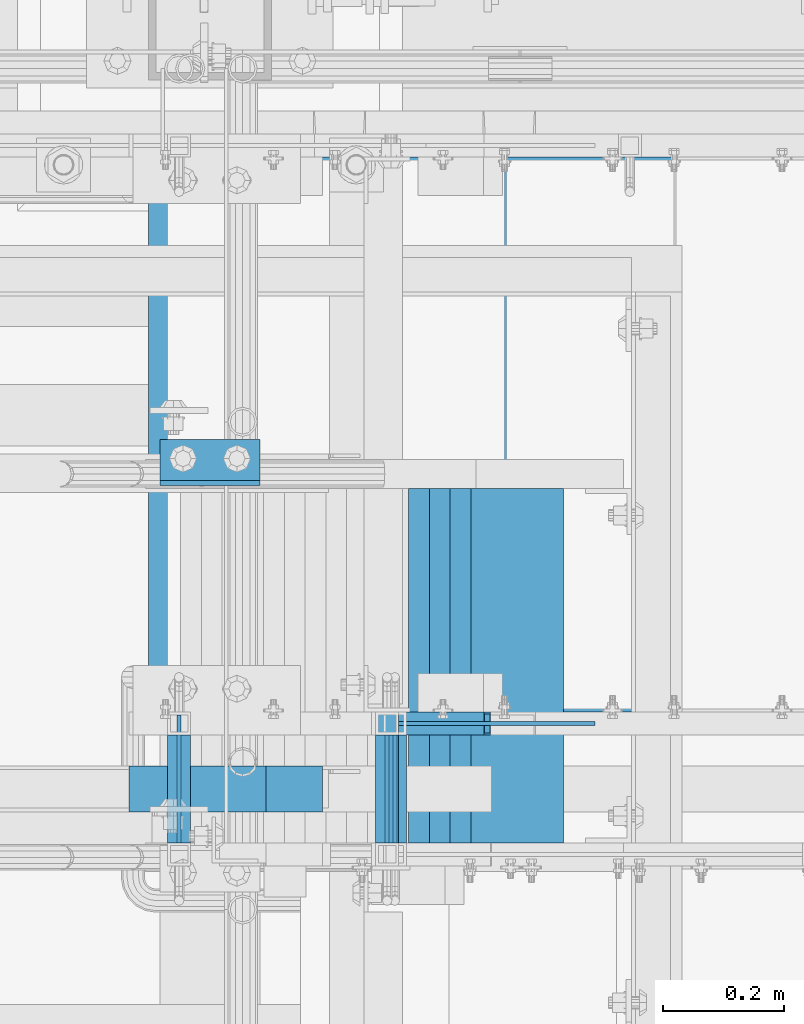
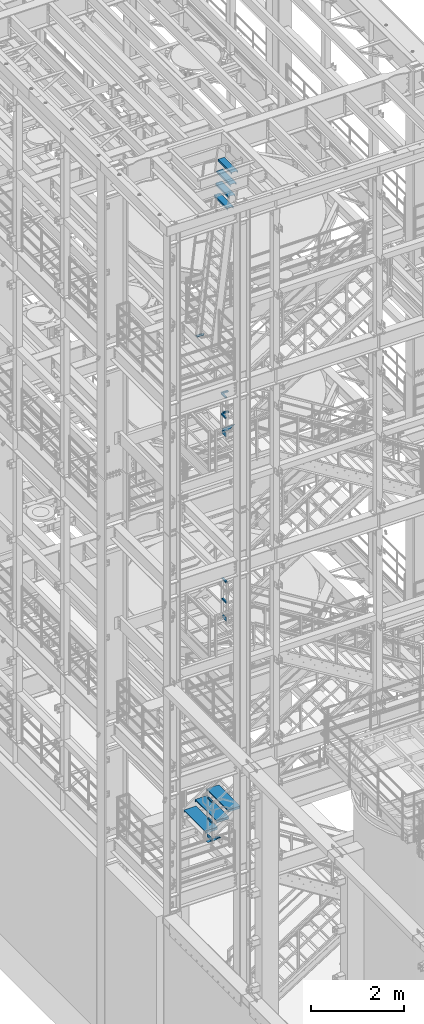
# One storey, part 1167 of 1876: 22 beams, 8 elements without a shape of their own.
"""IFC2X3 building model written with IfcOpenShell, lengths in millimetres."""

from ifc_helpers import new_model, si_unit, frame, origin_with_axes, place, context, subcontext, project, spatial, faceted_brep, material, type_object, element, aggregate, save


model = new_model("IFC2X3")

# Units and contexts
model_context = context("Model", 3, precision=1e-05, world=origin_with_axes())
body_context = subcontext(model_context, "Body", "Model", "MODEL_VIEW")
ifc_project = project(units=[si_unit("LENGTHUNIT", "METRE", prefix="MILLI"), si_unit("AREAUNIT", "SQUARE_METRE"), si_unit("VOLUMEUNIT", "CUBIC_METRE"), si_unit("MASSUNIT", "GRAM", prefix="KILO"), si_unit("TIMEUNIT", "SECOND"), si_unit("PLANEANGLEUNIT", "RADIAN"), si_unit("SOLIDANGLEUNIT", "STERADIAN"), si_unit("THERMODYNAMICTEMPERATUREUNIT", "DEGREE_CELSIUS"), si_unit("LUMINOUSINTENSITYUNIT", "LUMEN")], contexts=[model_context])

# Site, building, storey
site_placement = place(None, origin_with_axes())
site = spatial("IfcSite", under=ifc_project, at=site_placement, CompositionType="ELEMENT")
building_placement = place(site_placement, origin_with_axes())
building = spatial("IfcBuilding", under=site, at=building_placement, Name="Undefined", CompositionType="ELEMENT")
storey_placement = place(building_placement, origin_with_axes())
storey = spatial("IfcBuildingStorey", under=building, at=storey_placement, Name="Undefined", CompositionType="ELEMENT", Elevation=0.0)

# Assembly, beam
assembly_1_placement = place(storey_placement, origin_with_axes())
assembly_1 = element("IfcElementAssembly", 1, at=assembly_1_placement, inside=storey, Name="RAIL", AssemblyPlace="NOTDEFINED", PredefinedType="RIGID_FRAME")
ifc_material_1 = material(Name="STEEL/A36")
beam_type_1 = type_object("IfcBeamType", PredefinedType="NOTDEFINED")
beam_1_placement = place(assembly_1_placement, frame((2361.44126575365, -5734.04998108945, 15658.2768516082), z_axis=(0.0, 0.0, 1.0), x_axis=(-1.0, 0.0, 0.0)))
beam_1 = element("IfcBeam", 2, at=beam_1_placement, type_object=beam_type_1, material=ifc_material_1, Name="PLATE", context=body_context, shape_type="Brep", body=[
    faceted_brep([(163.772259212185, 3.17500000000018, -50.800000000072), (-0.223393296628274, 3.17500000000018, 50.7999999999993), (323.09127224857, 3.17500000000018, 50.7999999998556), (323.091272350217, 3.17500000000018, -50.8000000001448), (-0.223393296628274, -3.17500000000018, 50.7999999999993), (323.09127224857, -3.17500000000018, 50.7999999998556), (163.772259212185, -3.17500000000018, -50.800000000072), (323.091272350217, -3.17500000000018, -50.8000000001448)], [[[0, 1, 2, 3]], [[1, 4, 5, 2]], [[4, 6, 7, 5]], [[6, 0, 3, 7]], [[5, 7, 3, 2]], [[6, 4, 1, 0]]]),
])

assembly_2_placement = place(storey_placement, origin_with_axes())
assembly_2 = element("IfcElementAssembly", 3, at=assembly_2_placement, inside=storey, Name="RAIL", AssemblyPlace="NOTDEFINED", PredefinedType="RIGID_FRAME")
beam_2_placement = place(assembly_2_placement, frame((2019.30000344973, -5930.90000104941, 15658.2768521138), z_axis=(0.0, 0.0, 1.0), x_axis=(0.0, 1.0, 0.0)))
beam_2 = element("IfcBeam", 4, at=beam_2_placement, type_object=beam_type_1, material=ifc_material_1, Name="PLATE", context=body_context, shape_type="Brep", body=[
    faceted_brep([(0.0, 3.17500000000018, -50.8000000000002), (0.0, 3.17500000000018, 50.8000000000002), (177.799998770143, 3.1750000000111, 50.8000000000866), (177.799998770101, 3.1750000000111, -50.7999999999138), (0.0, -3.17500000000018, 50.8000000000002), (177.799998770144, -3.17499999998881, 50.8000000000866), (0.0, -3.17500000000018, -50.8000000000002), (177.799998770101, -3.17499999998881, -50.7999999999138)], [[[0, 1, 2, 3]], [[1, 4, 5, 2]], [[4, 6, 7, 5]], [[6, 0, 3, 7]], [[5, 7, 3, 2]], [[6, 4, 1, 0]]]),
])

assembly_3_placement = place(storey_placement, origin_with_axes())
assembly_3 = element("IfcElementAssembly", 5, at=assembly_3_placement, inside=storey, Name="RAIL", AssemblyPlace="NOTDEFINED", PredefinedType="RIGID_FRAME")
beam_3_placement = place(assembly_3_placement, frame((2032.00000460295, -5930.90001133696, 10829.9250009579), z_axis=(0.0, 0.0, 1.0), x_axis=(0.0, 1.0, 0.0)))
beam_3 = element("IfcBeam", 6, at=beam_3_placement, type_object=beam_type_1, material=ifc_material_1, Name="PLATE", context=body_context, shape_type="Brep", body=[
    faceted_brep([(0.0, 3.17500000000018, -50.8000000000002), (0.0, 3.17500000000018, 50.8000000000002), (177.799998770143, 3.1750000000111, 50.8000000000866), (177.799998770101, 3.1750000000111, -50.7999999999138), (0.0, -3.17500000000018, 50.8000000000002), (177.799998770144, -3.17499999998881, 50.8000000000866), (0.0, -3.17500000000018, -50.8000000000002), (177.799998770101, -3.17499999998881, -50.7999999999138)], [[[0, 1, 2, 3]], [[1, 4, 5, 2]], [[4, 6, 7, 5]], [[6, 0, 3, 7]], [[5, 7, 3, 2]], [[6, 4, 1, 0]]]),
])

assembly_4_placement = place(storey_placement, origin_with_axes())
assembly_4 = element("IfcElementAssembly", 7, at=assembly_4_placement, inside=storey, Name="RAIL", AssemblyPlace="NOTDEFINED", PredefinedType="RIGID_FRAME")
beam_4_placement = place(assembly_4_placement, frame((1676.40000844926, -5930.90000067151, 5203.82499734224), z_axis=(0.0, 0.0, 1.0), x_axis=(0.0, 1.0, 0.0)))
beam_4 = element("IfcBeam", 8, at=beam_4_placement, type_object=beam_type_1, material=ifc_material_1, Name="PLATE", context=body_context, shape_type="Brep", body=[
    faceted_brep([(0.0, 3.17500000000018, -50.8000000000002), (0.0, 3.17500000000018, 50.8000000000002), (211.137486447629, 3.17499999998313, 50.800000000062), (211.137486447659, 3.17499999998313, -50.7999999999374), (0.0, -3.17500000000018, 50.8000000000002), (211.13748644763, -3.17500000001701, 50.800000000062), (0.0, -3.17500000000018, -50.8000000000002), (211.137486447661, -3.17500000001701, -50.7999999999374)], [[[0, 1, 2, 3]], [[1, 4, 5, 2]], [[4, 6, 7, 5]], [[6, 0, 3, 7]], [[5, 7, 3, 2]], [[6, 4, 1, 0]]]),
])

# Beam
ifc_material_2 = material()
beam_type_2 = type_object("IfcBeamType", Name="HSS1-1/2X1-1/2X1/8", PredefinedType="NOTDEFINED")
beam_5_placement = place(assembly_2_placement, frame((2019.30000155065, -5930.89995081708, 16102.7768465107), z_axis=(0.0, 0.0, -1.0), x_axis=(0.0, 1.0, 0.0)))
beam_5 = element("IfcBeam", 9, at=beam_5_placement, type_object=beam_type_2, material=ifc_material_2, Name="RAIL", ObjectType="HSS1-1/2X1-1/2X1/8", context=body_context, shape_type="Brep", body=[
    faceted_brep([(-7.27595761418343e-12, 15.8749992829999, -15.8749992829999), (-7.27595761418343e-12, -15.8749992829999, -15.8749992829999), (177.800002232287, -15.8749992829999, -15.8749992829999), (177.800002232287, 15.8749992829999, -15.8749992829999), (5.45696821063757e-12, -15.8749992829999, 15.8749992829999), (177.800002232287, -15.8749992829999, 15.8749992829999), (5.45696821063757e-12, 15.8749992829999, 15.8749992829999), (177.800002232287, 15.8749992829999, 15.8749992829999), (0.0, 19.0499992349996, -19.0499992350001), (0.0, 19.0499992349996, 19.0499992349996), (177.800002232287, 19.0499992349996, 19.0499992349996), (177.800002232287, 19.0499992349996, -19.0499992349996), (0.0, -19.0499992349996, 19.0499992349996), (177.800002232287, -19.0499992349996, 19.0499992349996), (0.0, -19.0499992349996, -19.0499992350001), (177.800002232287, -19.0499992349996, -19.0499992349996)], [[[0, 1, 2, 3]], [[1, 4, 5, 2]], [[4, 6, 7, 5]], [[6, 0, 3, 7]], [[8, 9, 10, 11]], [[9, 12, 13, 10]], [[12, 14, 15, 13]], [[14, 8, 11, 15]], [[13, 15, 11, 10], [5, 7, 3, 2]], [[14, 12, 9, 8], [6, 4, 1, 0]]]),
])

beam_6_placement = place(assembly_2_placement, frame((2019.30000156608, -5930.90000376248, 16636.1769993921), z_axis=(0.0, 0.0, -1.0), x_axis=(0.0, 1.0, 0.0)))
beam_6 = element("IfcBeam", 10, at=beam_6_placement, type_object=beam_type_2, material=ifc_material_2, Name="RAIL", ObjectType="HSS1-1/2X1-1/2X1/8", context=body_context, shape_type="Brep", body=[
    faceted_brep([(-7.27595761418343e-12, 15.8749992829999, -15.8749992829999), (-7.27595761418343e-12, -15.8749992829999, -15.8749992829999), (177.800002232287, -15.8749992829999, -15.8749992829999), (177.800002232287, 15.8749992829999, -15.8749992829999), (5.45696821063757e-12, -15.8749992829999, 15.8749992829999), (177.800002232287, -15.8749992829999, 15.8749992829999), (5.45696821063757e-12, 15.8749992829999, 15.8749992829999), (177.800002232287, 15.8749992829999, 15.8749992829999), (0.0, 19.0499992349996, -19.0499992350001), (0.0, 19.0499992349996, 19.0499992349996), (177.800002232287, 19.0499992349996, 19.0499992349996), (177.800002232287, 19.0499992349996, -19.0499992349996), (0.0, -19.0499992349996, 19.0499992349996), (177.800002232287, -19.0499992349996, 19.0499992349996), (0.0, -19.0499992349996, -19.0499992350001), (177.800002232287, -19.0499992349996, -19.0499992349996)], [[[0, 1, 2, 3]], [[1, 4, 5, 2]], [[4, 6, 7, 5]], [[6, 0, 3, 7]], [[8, 9, 10, 11]], [[9, 12, 13, 10]], [[12, 14, 15, 13]], [[14, 8, 11, 15]], [[13, 15, 11, 10], [5, 7, 3, 2]], [[14, 12, 9, 8], [6, 4, 1, 0]]]),
])

aggregate(assembly_2, [beam_2, beam_5, beam_6])

beam_7_placement = place(assembly_3_placement, frame((2032.00000270388, -5930.90001131767, 11274.4249989489), z_axis=(0.0, 0.0, -1.0), x_axis=(0.0, 1.0, 0.0)))
beam_7 = element("IfcBeam", 11, at=beam_7_placement, type_object=beam_type_2, material=ifc_material_2, Name="RAIL", ObjectType="HSS1-1/2X1-1/2X1/8", context=body_context, shape_type="Brep", body=[
    faceted_brep([(-7.27595761418343e-12, 15.8749992829999, -15.8749992829999), (-7.27595761418343e-12, -15.8749992829999, -15.8749992829999), (177.800002232287, -15.8749992829999, -15.8749992829999), (177.800002232287, 15.8749992829999, -15.8749992829999), (5.45696821063757e-12, -15.8749992829999, 15.8749992829999), (177.800002232287, -15.8749992829999, 15.8749992829999), (5.45696821063757e-12, 15.8749992829999, 15.8749992829999), (177.800002232287, 15.8749992829999, 15.8749992829999), (0.0, 19.0499992349996, -19.0499992350001), (0.0, 19.0499992349996, 19.0499992349996), (177.800002232287, 19.0499992349996, 19.0499992349996), (177.800002232287, 19.0499992349996, -19.0499992349996), (0.0, -19.0499992349996, 19.0499992349996), (177.800002232287, -19.0499992349996, 19.0499992349996), (0.0, -19.0499992349996, -19.0499992350001), (177.800002232287, -19.0499992349996, -19.0499992349996)], [[[0, 1, 2, 3]], [[1, 4, 5, 2]], [[4, 6, 7, 5]], [[6, 0, 3, 7]], [[8, 9, 10, 11]], [[9, 12, 13, 10]], [[12, 14, 15, 13]], [[14, 8, 11, 15]], [[13, 15, 11, 10], [5, 7, 3, 2]], [[14, 12, 9, 8], [6, 4, 1, 0]]]),
])

beam_8_placement = place(assembly_3_placement, frame((2032.00000271931, -5930.89999587786, 11807.8249941664), z_axis=(0.0, 0.0, -1.0), x_axis=(0.0, 1.0, 0.0)))
beam_8 = element("IfcBeam", 12, at=beam_8_placement, type_object=beam_type_2, material=ifc_material_2, Name="RAIL", ObjectType="HSS1-1/2X1-1/2X1/8", context=body_context, shape_type="Brep", body=[
    faceted_brep([(-7.27595761418343e-12, 15.8749992829999, -15.8749992829999), (-7.27595761418343e-12, -15.8749992829999, -15.8749992829999), (177.800002232287, -15.8749992829999, -15.8749992829999), (177.800002232287, 15.8749992829999, -15.8749992829999), (5.45696821063757e-12, -15.8749992829999, 15.8749992829999), (177.800002232287, -15.8749992829999, 15.8749992829999), (5.45696821063757e-12, 15.8749992829999, 15.8749992829999), (177.800002232287, 15.8749992829999, 15.8749992829999), (0.0, 19.0499992349996, -19.0499992350001), (0.0, 19.0499992349996, 19.0499992349996), (177.800002232287, 19.0499992349996, 19.0499992349996), (177.800002232287, 19.0499992349996, -19.0499992349996), (0.0, -19.0499992349996, 19.0499992349996), (177.800002232287, -19.0499992349996, 19.0499992349996), (0.0, -19.0499992349996, -19.0499992350001), (177.800002232287, -19.0499992349996, -19.0499992349996)], [[[0, 1, 2, 3]], [[1, 4, 5, 2]], [[4, 6, 7, 5]], [[6, 0, 3, 7]], [[8, 9, 10, 11]], [[9, 12, 13, 10]], [[12, 14, 15, 13]], [[14, 8, 11, 15]], [[13, 15, 11, 10], [5, 7, 3, 2]], [[14, 12, 9, 8], [6, 4, 1, 0]]]),
])

aggregate(assembly_3, [beam_3, beam_7, beam_8])

beam_9_placement = place(assembly_4_placement, frame((1676.40000857378, -5930.90000047004, 5664.2), z_axis=(0.0, 0.0, -1.0), x_axis=(0.0, 1.0, 0.0)))
beam_9 = element("IfcBeam", 13, at=beam_9_placement, type_object=beam_type_2, material=ifc_material_2, Name="RAIL", ObjectType="HSS1-1/2X1-1/2X1/8", context=body_context, shape_type="Brep", body=[
    faceted_brep([(-7.27595761418343e-12, 15.8749992829999, -15.8749992829999), (-7.27595761418343e-12, -15.8749992829999, -15.8749992829999), (177.800002232287, -15.8749992829999, -15.8749992829999), (177.800002232287, 15.8749992829999, -15.8749992829999), (5.45696821063757e-12, -15.8749992829999, 15.8749992829999), (177.800002232287, -15.8749992829999, 15.8749992829999), (5.45696821063757e-12, 15.8749992829999, 15.8749992829999), (177.800002232287, 15.8749992829999, 15.8749992829999), (0.0, 19.0499992349996, -19.0499992350001), (0.0, 19.0499992349996, 19.0499992349996), (177.800002232287, 19.0499992349996, 19.0499992349996), (177.800002232287, 19.0499992349996, -19.0499992349996), (0.0, -19.0499992349996, 19.0499992349996), (177.800002232287, -19.0499992349996, 19.0499992349996), (0.0, -19.0499992349996, -19.0499992350001), (177.800002232287, -19.0499992349996, -19.0499992349996)], [[[0, 1, 2, 3]], [[1, 4, 5, 2]], [[4, 6, 7, 5]], [[6, 0, 3, 7]], [[8, 9, 10, 11]], [[9, 12, 13, 10]], [[12, 14, 15, 13]], [[14, 8, 11, 15]], [[13, 15, 11, 10], [5, 7, 3, 2]], [[14, 12, 9, 8], [6, 4, 1, 0]]]),
])

beam_10_placement = place(assembly_4_placement, frame((1676.40000803678, -5930.90000047004, 6197.60000003809), z_axis=(0.0, 0.0, -1.0), x_axis=(0.0, 1.0, 0.0)))
beam_10 = element("IfcBeam", 14, at=beam_10_placement, type_object=beam_type_2, material=ifc_material_2, Name="RAIL", ObjectType="HSS1-1/2X1-1/2X1/8", context=body_context, shape_type="Brep", body=[
    faceted_brep([(-7.27595761418343e-12, 15.8749992829999, -15.8749992829999), (-7.27595761418343e-12, -15.8749992829999, -15.8749992829999), (177.800002232287, -15.8749992829999, -15.8749992829999), (177.800002232287, 15.8749992829999, -15.8749992829999), (5.45696821063757e-12, -15.8749992829999, 15.8749992829999), (177.800002232287, -15.8749992829999, 15.8749992829999), (5.45696821063757e-12, 15.8749992829999, 15.8749992829999), (177.800002232287, 15.8749992829999, 15.8749992829999), (0.0, 19.0499992349996, -19.0499992350001), (0.0, 19.0499992349996, 19.0499992349996), (177.800002232287, 19.0499992349996, 19.0499992349996), (177.800002232287, 19.0499992349996, -19.0499992349996), (0.0, -19.0499992349996, 19.0499992349996), (177.800002232287, -19.0499992349996, 19.0499992349996), (0.0, -19.0499992349996, -19.0499992350001), (177.800002232287, -19.0499992349996, -19.0499992349996)], [[[0, 1, 2, 3]], [[1, 4, 5, 2]], [[4, 6, 7, 5]], [[6, 0, 3, 7]], [[8, 9, 10, 11]], [[9, 12, 13, 10]], [[12, 14, 15, 13]], [[14, 8, 11, 15]], [[13, 15, 11, 10], [5, 7, 3, 2]], [[14, 12, 9, 8], [6, 4, 1, 0]]]),
])

aggregate(assembly_4, [beam_4, beam_9, beam_10])

beam_11_placement = place(assembly_1_placement, frame((2019.29999422474, -5734.05000114554, 16102.7768508083), z_axis=(0.0, 0.0, 1.0), x_axis=(1.0, 0.0, 0.0)))
beam_11 = element("IfcBeam", 15, at=beam_11_placement, type_object=beam_type_2, material=ifc_material_2, Name="RAIL", ObjectType="HSS1-1/2X1-1/2X1/8", context=body_context, shape_type="Brep", body=[
    faceted_brep([(19.0500000000002, 15.8749992829999, -15.8749992829999), (19.0500000000002, -15.8749992829999, -15.8749992829999), (169.383975712996, -15.8749992829999, -15.8749992829999), (169.383975712996, 15.8749992829999, -15.8749992829999), (19.0500000000002, -15.8749992829999, 15.8749992829999), (160.346381729512, -15.8749992829999, 15.8749992829999), (19.0500000000002, 15.8749992829999, 15.8749992829999), (160.346381729512, 15.8749992829999, 15.8749992829999), (19.0500000000002, 19.0499992349996, -19.0499992350001), (19.0500000000002, 19.0499992349996, 19.0499992350001), (159.442622304009, 19.0499992349996, 19.0499992349996), (170.2877351385, 19.0499992349996, -19.0499992349996), (19.0500000000002, -19.0499992349996, 19.0499992350001), (159.442622304009, -19.0499992349996, 19.0499992349996), (19.0500000000002, -19.0499992349996, -19.0499992350001), (170.2877351385, -19.0499992349996, -19.0499992349996)], [[[0, 1, 2, 3]], [[1, 4, 5, 2]], [[4, 6, 7, 5]], [[6, 0, 3, 7]], [[8, 9, 10, 11]], [[9, 12, 13, 10]], [[12, 14, 15, 13]], [[14, 8, 11, 15]], [[13, 15, 11, 10], [5, 7, 3, 2]], [[12, 9, 8, 14], [4, 1, 0, 6]]]),
])

beam_12_placement = place(assembly_1_placement, frame((2184.16517293629, -5734.05000114554, 16636.1768508089), z_axis=(0.0, 0.0, -1.0), x_axis=(-1.0, 0.0, 0.0)))
beam_12 = element("IfcBeam", 16, at=beam_12_placement, type_object=beam_type_2, material=ifc_material_2, Name="RAIL", ObjectType="HSS1-1/2X1-1/2X1/8", context=body_context, shape_type="Brep", body=[
    faceted_brep([(4.51879699173378, 15.8749992829999, -15.8749992830017), (4.51879699173378, -15.8749992829999, -15.8749992830017), (180.740178000636, -15.8749992829999, -15.8749992830017), (180.740178000636, 15.8749992829999, -15.8749992830017), (-4.51879699175015, -15.8749992829999, 15.8749992830017), (148.990179434636, -15.8749992829999, 15.8749992830017), (-4.51879699175015, 15.8749992829999, 15.8749992830017), (148.990179434636, 15.8749992829999, 15.8749992830017), (5.4225564172375, 19.0499992349996, -19.0499992350015), (-5.42255641725387, 19.0499992349996, 19.0499992350015), (145.815179482636, 19.0499992349996, 19.0499992350015), (183.915177952636, 19.0499992349996, -19.0499992350015), (-5.42255641725387, -19.0499992349996, 19.0499992350015), (145.815179482636, -19.0499992349996, 19.0499992350015), (5.4225564172375, -19.0499992349996, -19.0499992350015), (183.915177952636, -19.0499992349996, -19.0499992350015)], [[[0, 1, 2, 3]], [[1, 4, 5, 2]], [[4, 6, 7, 5]], [[6, 0, 3, 7]], [[8, 9, 10, 11]], [[9, 12, 13, 10]], [[12, 14, 15, 13]], [[14, 8, 11, 15]], [[13, 15, 11, 10], [5, 7, 3, 2]], [[14, 12, 9, 8], [6, 4, 1, 0]]]),
])

aggregate(assembly_1, [beam_1, beam_11, beam_12])

# Assembly, beams
assembly_5_placement = place(storey_placement, origin_with_axes())
assembly_5 = element("IfcElementAssembly", 17, at=assembly_5_placement, inside=storey, Name="STRINGER", AssemblyPlace="NOTDEFINED", PredefinedType="RIGID_FRAME")
beam_type_3 = type_object("IfcBeamType", PredefinedType="NOTDEFINED")
beam_13_placement = place(assembly_5_placement, frame((2338.38749953646, -5710.23700113625, 5664.19999975688), z_axis=(-1.0, 0.0, 0.0), x_axis=(0.0, 1.0, 0.0)))
beam_13 = element("IfcBeam", 18, at=beam_13_placement, type_object=beam_type_3, material=ifc_material_1, Name="TREAD", context=body_context, shape_type="Brep", body=[
    faceted_brep([(-7.45785655453801e-11, 53.9750000000167, -153.9875), (-7.45785655453801e-11, 53.9750000000167, 153.987506103515), (0.0, 9.52499999999964, 153.9875), (-7.45785655453801e-11, 9.52499999999964, -153.9875), (-4.76300000007541, 53.9750000000167, -153.9875), (-4.76300000007541, 53.9750000000167, 153.987506103515), (-4.76300000007541, -9.52499999998327, -153.9875), (-4.76300000007541, -9.52500000019427, 153.987536621094), (909.637000008669, -9.52500000248983, 153.987506103515), (909.637000008669, 53.9749999975102, 153.987506103515), (904.87400000867, 53.9749999975102, 153.987506103515), (904.87400000867, 9.52499999999964, 153.987506103515), (-7.45785655453801e-11, -9.52500000019427, 153.987536621094), (904.87400000867, -9.52500000248983, 153.987506103515), (904.87400000867, 9.52499999999964, -153.9875), (909.637000008669, -9.52500000248983, -153.9875), (909.637000008669, 53.9749999975102, -153.9875), (904.87400000867, 53.9749999975102, -153.9875)], [[[0, 1, 2, 3]], [[1, 0, 4, 5]], [[5, 4, 6, 7]], [[8, 9, 10, 11, 2, 1, 5, 7, 12, 13]], [[14, 3, 2, 11]], [[15, 8, 13, 12, 7, 6]], [[9, 16, 17, 10]], [[16, 9, 8, 15]], [[16, 15, 6, 4, 0, 3, 14, 17]], [[10, 17, 14, 11]]]),
])
beam_14_placement = place(assembly_5_placement, frame((2058.98749992655, -5710.23700113625, 5486.39999983764), z_axis=(-1.0, 0.0, 0.0), x_axis=(0.0, 1.0, 0.0)))
beam_14 = element("IfcBeam", 19, at=beam_14_placement, type_object=beam_type_3, material=ifc_material_1, Name="TREAD", context=body_context, shape_type="Brep", body=[
    faceted_brep([(-7.45785655453801e-11, 53.9750000000167, -153.9875), (-7.45785655453801e-11, 53.9750000000167, 153.987506103515), (0.0, 9.52499999999964, 153.9875), (-7.45785655453801e-11, 9.52499999999964, -153.9875), (-4.76300000007541, 53.9750000000167, -153.9875), (-4.76300000007541, 53.9750000000167, 153.987506103515), (-4.76300000007541, -9.52499999998327, -153.9875), (-4.76300000007541, -9.52500000019427, 153.987536621094), (909.637000008669, -9.52500000248983, 153.987506103515), (909.637000008669, 53.9749999975102, 153.987506103515), (904.87400000867, 53.9749999975102, 153.987506103515), (904.87400000867, 9.52499999999964, 153.987506103515), (-7.45785655453801e-11, -9.52500000019427, 153.987536621094), (904.87400000867, -9.52500000248983, 153.987506103515), (904.87400000867, 9.52499999999964, -153.9875), (909.637000008669, -9.52500000248983, -153.9875), (909.637000008669, 53.9749999975102, -153.9875), (904.87400000867, 53.9749999975102, -153.9875)], [[[0, 1, 2, 3]], [[1, 0, 4, 5]], [[5, 4, 6, 7]], [[8, 9, 10, 11, 2, 1, 5, 7, 12, 13]], [[14, 3, 2, 11]], [[15, 8, 13, 12, 7, 6]], [[9, 16, 17, 10]], [[16, 9, 8, 15]], [[16, 15, 6, 4, 0, 3, 14, 17]], [[10, 17, 14, 11]]]),
])
beam_15_placement = place(assembly_5_placement, frame((1779.58750031664, -5710.23700113625, 5308.59999991841), z_axis=(-1.0, 0.0, 0.0), x_axis=(0.0, 1.0, 0.0)))
beam_15 = element("IfcBeam", 20, at=beam_15_placement, type_object=beam_type_3, material=ifc_material_1, Name="TREAD", context=body_context, shape_type="Brep", body=[
    faceted_brep([(-7.45785655453801e-11, 53.9750000000167, -153.9875), (-7.45785655453801e-11, 53.9750000000167, 153.987506103515), (0.0, 9.52499999999964, 153.9875), (-7.45785655453801e-11, 9.52499999999964, -153.9875), (-4.76300000007541, 53.9750000000167, -153.9875), (-4.76300000007541, 53.9750000000167, 153.987506103515), (-4.76300000007541, -9.52499999998327, -153.9875), (-4.76300000007541, -9.52500000019427, 153.987536621094), (909.637000008669, -9.52500000248983, 153.987506103515), (909.637000008669, 53.9749999975102, 153.987506103515), (904.87400000867, 53.9749999975102, 153.987506103515), (904.87400000867, 9.52499999999964, 153.987506103515), (-7.45785655453801e-11, -9.52500000019427, 153.987536621094), (904.87400000867, -9.52500000248983, 153.987506103515), (904.87400000867, 9.52499999999964, -153.9875), (909.637000008669, -9.52500000248983, -153.9875), (909.637000008669, 53.9749999975102, -153.9875), (904.87400000867, 53.9749999975102, -153.9875)], [[[0, 1, 2, 3]], [[1, 0, 4, 5]], [[5, 4, 6, 7]], [[8, 9, 10, 11, 2, 1, 5, 7, 12, 13]], [[14, 3, 2, 11]], [[15, 8, 13, 12, 7, 6]], [[9, 16, 17, 10]], [[16, 9, 8, 15]], [[16, 15, 6, 4, 0, 3, 14, 17]], [[10, 17, 14, 11]]]),
])
aggregate(assembly_5, [beam_13, beam_14, beam_15])

assembly_6_placement = place(storey_placement, origin_with_axes())
assembly_6 = element("IfcElementAssembly", 21, at=assembly_6_placement, inside=storey, Name="RIGHT STRINGER", AssemblyPlace="NOTDEFINED", PredefinedType="RIGID_FRAME")
beam_type_4 = type_object("IfcBeamType", PredefinedType="NOTDEFINED")
beam_16_placement = place(assembly_6_placement, frame((2233.69414204589, -5930.9, 22434.55), z_axis=(1.0, 0.0, 0.0), x_axis=(0.0, 1.0, 0.0)))
beam_16 = element("IfcBeam", 22, at=beam_16_placement, type_object=beam_type_4, material=ifc_material_1, Name="TREAD", context=body_context, shape_type="Brep", body=[
    faceted_brep([(0.0, -25.4000000000015, -76.1999999999998), (0.0, 25.4000000000015, -76.1999999999998), (584.199999999999, 25.4000000000015, -76.1999999999998), (584.199999999999, -25.4000000000015, -76.1999999999998), (0.0, 25.4000000000015, 76.1999999999998), (584.199999999999, 25.4000000000015, 76.1999999999998), (0.0, -25.4000000000015, 76.1999999999998), (584.199999999999, -25.4000000000015, 76.1999999999998), (0.0, -25.4000000000015, 63.5), (584.199999999999, -25.4000000000015, 63.5), (0.0, -22.2249999999985, 63.5), (584.199999999999, -22.2249999999985, 63.5), (0.0, -22.2249999999985, 73.0250000000001), (584.199999999999, -22.2249999999985, 73.0250000000001), (0.0, 22.2249999999985, 73.0250000000001), (584.199999999999, 22.2249999999985, 73.0250000000001), (0.0, 22.2249999999985, -73.0250000000001), (584.199999999999, 22.2249999999985, -73.0250000000001), (0.0, -22.2249999999985, -73.0250000000001), (584.199999999999, -22.2249999999985, -73.0250000000001), (0.0, -22.2249999999985, -63.5), (584.199999999999, -22.2249999999985, -63.5), (0.0, -25.4000000000015, -63.5), (584.199999999999, -25.4000000000015, -63.5)], [[[0, 1, 2, 3]], [[1, 4, 5, 2]], [[4, 6, 7, 5]], [[6, 8, 9, 7]], [[8, 10, 11, 9]], [[10, 12, 13, 11]], [[12, 14, 15, 13]], [[14, 16, 17, 15]], [[16, 18, 19, 17]], [[18, 20, 21, 19]], [[20, 22, 23, 21]], [[22, 0, 3, 23]], [[5, 7, 9, 11, 13, 15, 17, 19, 21, 23, 3, 2]], [[22, 20, 18, 16, 14, 12, 10, 8, 6, 4, 1, 0]]]),
])
beam_17_placement = place(assembly_6_placement, frame((2199.50453257617, -5930.9, 22136.1), z_axis=(1.0, 0.0, 0.0), x_axis=(0.0, 1.0, 0.0)))
beam_17 = element("IfcBeam", 23, at=beam_17_placement, type_object=beam_type_4, material=ifc_material_1, Name="TREAD", context=body_context, shape_type="Brep", body=[
    faceted_brep([(0.0, -25.4000000000015, -76.1999999999998), (0.0, 25.4000000000015, -76.1999999999998), (584.199999999999, 25.4000000000015, -76.1999999999998), (584.199999999999, -25.4000000000015, -76.1999999999998), (0.0, 25.4000000000015, 76.1999999999998), (584.199999999999, 25.4000000000015, 76.1999999999998), (0.0, -25.4000000000015, 76.1999999999998), (584.199999999999, -25.4000000000015, 76.1999999999998), (0.0, -25.4000000000015, 63.5), (584.199999999999, -25.4000000000015, 63.5), (0.0, -22.2249999999985, 63.5), (584.199999999999, -22.2249999999985, 63.5), (0.0, -22.2249999999985, 73.0250000000001), (584.199999999999, -22.2249999999985, 73.0250000000001), (0.0, 22.2249999999985, 73.0250000000001), (584.199999999999, 22.2249999999985, 73.0250000000001), (0.0, 22.2249999999985, -73.0250000000001), (584.199999999999, 22.2249999999985, -73.0250000000001), (0.0, -22.2249999999985, -73.0250000000001), (584.199999999999, -22.2249999999985, -73.0250000000001), (0.0, -22.2249999999985, -63.5), (584.199999999999, -22.2249999999985, -63.5), (0.0, -25.4000000000015, -63.5), (584.199999999999, -25.4000000000015, -63.5)], [[[0, 1, 2, 3]], [[1, 4, 5, 2]], [[4, 6, 7, 5]], [[6, 8, 9, 7]], [[8, 10, 11, 9]], [[10, 12, 13, 11]], [[12, 14, 15, 13]], [[14, 16, 17, 15]], [[16, 18, 19, 17]], [[18, 20, 21, 19]], [[20, 22, 23, 21]], [[22, 0, 3, 23]], [[5, 7, 9, 11, 13, 15, 17, 19, 21, 23, 3, 2]], [[22, 20, 18, 16, 14, 12, 10, 8, 6, 4, 1, 0]]]),
])
beam_18_placement = place(assembly_6_placement, frame((2165.31492310644, -5930.9, 21837.65), z_axis=(1.0, 0.0, 0.0), x_axis=(0.0, 1.0, 0.0)))
beam_18 = element("IfcBeam", 24, at=beam_18_placement, type_object=beam_type_4, material=ifc_material_1, Name="TREAD", context=body_context, shape_type="Brep", body=[
    faceted_brep([(0.0, -25.4000000000015, -76.1999999999998), (0.0, 25.4000000000015, -76.1999999999998), (584.199999999999, 25.4000000000015, -76.1999999999998), (584.199999999999, -25.4000000000015, -76.1999999999998), (0.0, 25.4000000000015, 76.1999999999998), (584.199999999999, 25.4000000000015, 76.1999999999998), (0.0, -25.4000000000015, 76.1999999999998), (584.199999999999, -25.4000000000015, 76.1999999999998), (0.0, -25.4000000000015, 63.5), (584.199999999999, -25.4000000000015, 63.5), (0.0, -22.2249999999985, 63.5), (584.199999999999, -22.2249999999985, 63.5), (0.0, -22.2249999999985, 73.0250000000001), (584.199999999999, -22.2249999999985, 73.0250000000001), (0.0, 22.2249999999985, 73.0250000000001), (584.199999999999, 22.2249999999985, 73.0250000000001), (0.0, 22.2249999999985, -73.0250000000001), (584.199999999999, 22.2249999999985, -73.0250000000001), (0.0, -22.2249999999985, -73.0250000000001), (584.199999999999, -22.2249999999985, -73.0250000000001), (0.0, -22.2249999999985, -63.5), (584.199999999999, -22.2249999999985, -63.5), (0.0, -25.4000000000015, -63.5), (584.199999999999, -25.4000000000015, -63.5)], [[[0, 1, 2, 3]], [[1, 4, 5, 2]], [[4, 6, 7, 5]], [[6, 8, 9, 7]], [[8, 10, 11, 9]], [[10, 12, 13, 11]], [[12, 14, 15, 13]], [[14, 16, 17, 15]], [[16, 18, 19, 17]], [[18, 20, 21, 19]], [[20, 22, 23, 21]], [[22, 0, 3, 23]], [[5, 7, 9, 11, 13, 15, 17, 19, 21, 23, 3, 2]], [[22, 20, 18, 16, 14, 12, 10, 8, 6, 4, 1, 0]]]),
])
beam_19_placement = place(assembly_6_placement, frame((2131.12531363671, -5930.9, 21539.2), z_axis=(1.0, 0.0, 0.0), x_axis=(0.0, 1.0, 0.0)))
beam_19 = element("IfcBeam", 25, at=beam_19_placement, type_object=beam_type_4, material=ifc_material_1, Name="TREAD", context=body_context, shape_type="Brep", body=[
    faceted_brep([(0.0, -25.4000000000015, -76.1999999999998), (0.0, 25.4000000000015, -76.1999999999998), (584.199999999999, 25.4000000000015, -76.1999999999998), (584.199999999999, -25.4000000000015, -76.1999999999998), (0.0, 25.4000000000015, 76.1999999999998), (584.199999999999, 25.4000000000015, 76.1999999999998), (0.0, -25.4000000000015, 76.1999999999998), (584.199999999999, -25.4000000000015, 76.1999999999998), (0.0, -25.4000000000015, 63.5), (584.199999999999, -25.4000000000015, 63.5), (0.0, -22.2249999999985, 63.5), (584.199999999999, -22.2249999999985, 63.5), (0.0, -22.2249999999985, 73.0250000000001), (584.199999999999, -22.2249999999985, 73.0250000000001), (0.0, 22.2249999999985, 73.0250000000001), (584.199999999999, 22.2249999999985, 73.0250000000001), (0.0, 22.2249999999985, -73.0250000000001), (584.199999999999, 22.2249999999985, -73.0250000000001), (0.0, -22.2249999999985, -73.0250000000001), (584.199999999999, -22.2249999999985, -73.0250000000001), (0.0, -22.2249999999985, -63.5), (584.199999999999, -22.2249999999985, -63.5), (0.0, -25.4000000000015, -63.5), (584.199999999999, -25.4000000000015, -63.5)], [[[0, 1, 2, 3]], [[1, 4, 5, 2]], [[4, 6, 7, 5]], [[6, 8, 9, 7]], [[8, 10, 11, 9]], [[10, 12, 13, 11]], [[12, 14, 15, 13]], [[14, 16, 17, 15]], [[16, 18, 19, 17]], [[18, 20, 21, 19]], [[20, 22, 23, 21]], [[22, 0, 3, 23]], [[5, 7, 9, 11, 13, 15, 17, 19, 21, 23, 3, 2]], [[22, 20, 18, 16, 14, 12, 10, 8, 6, 4, 1, 0]]]),
])

# Assembly, beam
assembly_7_placement = place(storey_placement, origin_with_axes())
assembly_7 = element("IfcElementAssembly", 26, at=assembly_7_placement, inside=storey, Name="ref.", AssemblyPlace="NOTDEFINED", PredefinedType="RIGID_FRAME")
ifc_material_3 = material(Name="STEEL/Steel_Undefined")
beam_type_5 = type_object("IfcBeamType", PredefinedType="NOTDEFINED")
beam_20_placement = place(assembly_7_placement, frame((1819.28655484766, -5842.00000113818, 5153.02500000168), z_axis=(0.0, -1.0, 0.0), x_axis=(1.0, 0.0, 0.0)))
beam_20 = element("IfcBeam", 27, at=beam_20_placement, type_object=beam_type_5, material=ifc_material_3, Name="ref.", context=body_context, shape_type="Brep", body=[
    faceted_brep([(0.0, 3.17500000000018, -38.1000000000004), (0.0, 3.17500000000018, 38.1000000000004), (93.090723318018, 3.17500000000018, 38.1000000000004), (93.090723318018, 3.17500000000018, -38.1000000000004), (0.0, -3.17500000000018, 38.1000000000004), (93.090723318018, -3.17500000000018, 38.1000000000004), (0.0, -3.17500000000018, -38.1000000000004), (93.090723318018, -3.17500000000018, -38.1000000000004)], [[[0, 1, 2, 3]], [[1, 4, 5, 2]], [[4, 6, 7, 5]], [[6, 0, 3, 7]], [[5, 7, 3, 2]], [[6, 4, 1, 0]]]),
])
aggregate(assembly_7, [beam_20])

assembly_8_placement = place(storey_placement, origin_with_axes())
assembly_8 = element("IfcElementAssembly", 28, at=assembly_8_placement, inside=storey, Name="ref.", AssemblyPlace="NOTDEFINED", PredefinedType="RIGID_FRAME")
beam_21_placement = place(assembly_8_placement, frame((1593.8499991874, -5842.00000113818, 5127.625), z_axis=(0.0, -1.0, 0.0), x_axis=(1.0, 0.0, 0.0)))
beam_21 = element("IfcBeam", 29, at=beam_21_placement, type_object=beam_type_5, material=ifc_material_3, Name="ref.", context=body_context, shape_type="Brep", body=[
    faceted_brep([(0.0, 3.17500000000018, -38.1000000000004), (0.0, 3.17500000000018, 38.1000000000004), (225.425000826699, 3.17500000000018, 38.1000000000004), (225.425000826699, 3.17500000000018, -38.1000000000004), (0.0, -3.17500000000018, 38.1000000000004), (225.425000826699, -3.17500000000018, 38.1000000000004), (0.0, -3.17500000000018, -38.1000000000004), (225.425000826699, -3.17500000000018, -38.1000000000004)], [[[0, 1, 2, 3]], [[1, 4, 5, 2]], [[4, 6, 7, 5]], [[6, 0, 3, 7]], [[5, 7, 3, 2]], [[6, 4, 1, 0]]]),
])
aggregate(assembly_8, [beam_21])

# Beam
beam_type_6 = type_object("IfcBeamType", Name="L3X2X5/16", PredefinedType="NOTDEFINED")
beam_22_placement = place(assembly_6_placement, frame((1644.71497279085, -5303.8375, 18008.6), z_axis=(0.0, 1.0, 0.0), x_axis=(1.0, 0.0, 0.0)))
beam_22 = element("IfcBeam", 30, at=beam_22_placement, type_object=beam_type_6, material=ifc_material_1, Name="ANGLE", ObjectType="L3X2X5/16", context=body_context, shape_type="Brep", body=[
    faceted_brep([(0.0, 25.3999999999996, -38.1000000000004), (0.0, 25.3999999999996, 38.1000000000004), (165.1, 25.4000000000015, 38.1000000000004), (165.1, 25.4000000000015, -38.1000000000004), (0.0, 17.4625000000015, 38.1000000000004), (165.1, 17.4625000000015, 38.1000000000004), (0.0, 17.4625000000015, -30.1625000000004), (165.1, 17.4625000000015, -30.1625000000004), (0.0, -25.4000000000015, -30.1625000000004), (165.1, -25.4000000000015, -30.1625000000004), (0.0, -25.3999999999996, -38.1000000000004), (165.1, -25.4000000000015, -38.1000000000004)], [[[0, 1, 2, 3]], [[1, 4, 5, 2]], [[4, 6, 7, 5]], [[6, 8, 9, 7]], [[8, 10, 11, 9]], [[10, 0, 3, 11]], [[5, 7, 9, 11, 3, 2]], [[10, 8, 6, 4, 1, 0]]]),
])

aggregate(assembly_6, [beam_16, beam_17, beam_18, beam_22, beam_19])

save(model, "model.ifc")
